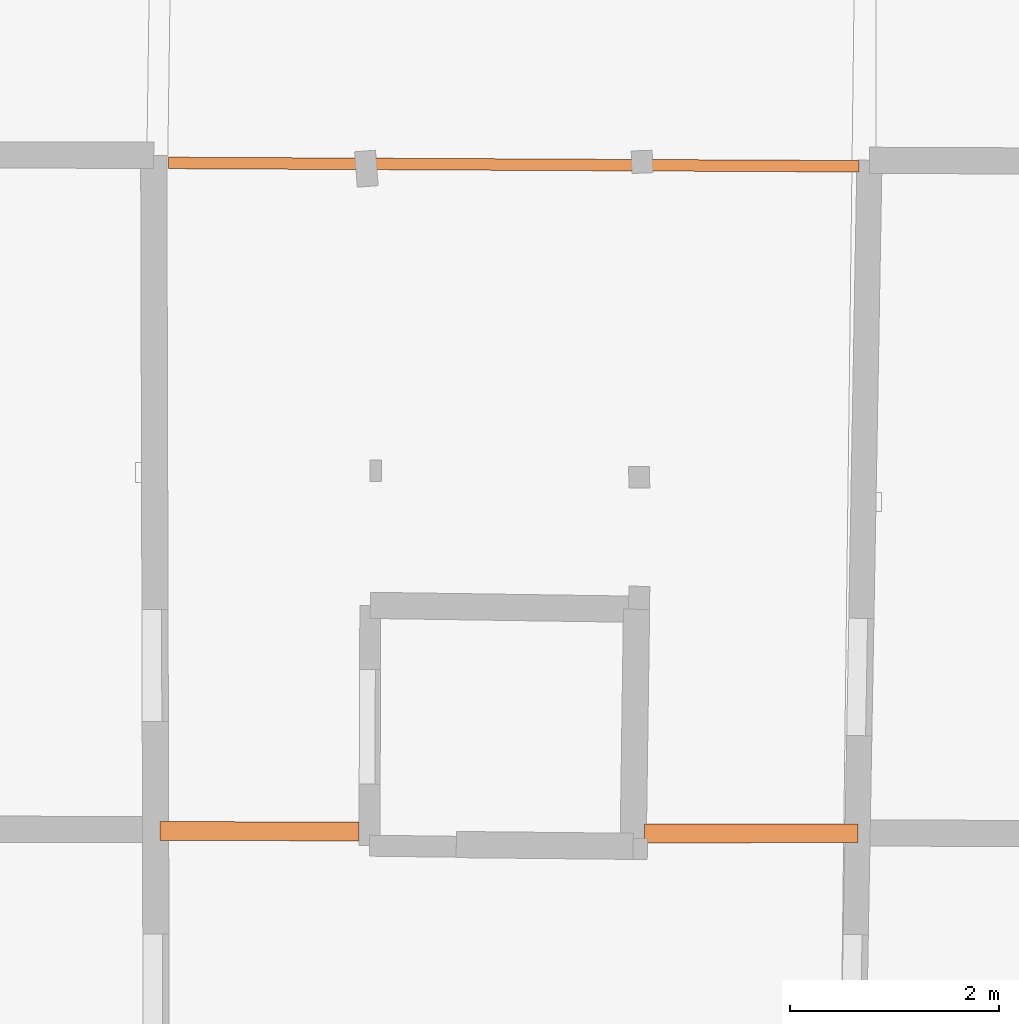
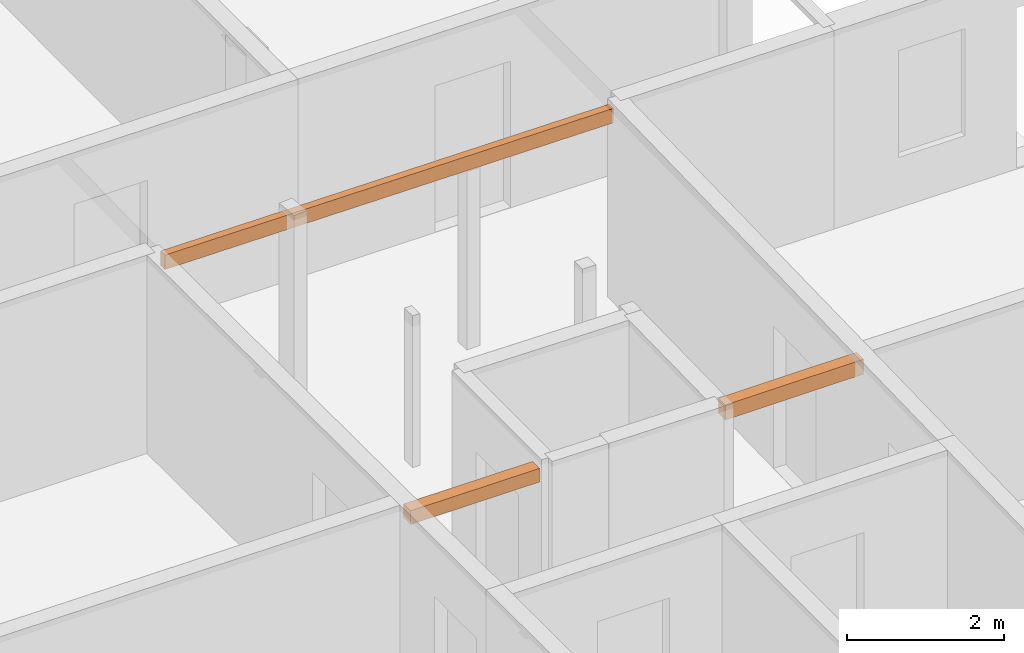
# One storey, part 17 of 17: 3 proxies.
"""IFC2X3 building model written with IfcOpenShell, lengths in metres."""

from ifc_helpers import new_model, entity, si_unit, converted_unit, derived_unit, direction, frame, origin, place, context, subcontext, project, spatial, polyline, outline, extrude, source, transform, mapped, material, type_object, type_shapes, element, save


model = new_model("IFC2X3")

# Units and contexts
model_context = context("Model", 3, precision=1e-05, world=origin(), true_north=direction((0.0, 1.0)))
body_context = subcontext(model_context, "Body", "Model", "MODEL_VIEW")
ifc_project = project(units=[si_unit("LENGTHUNIT", "METRE"), si_unit("AREAUNIT", "SQUARE_METRE"), si_unit("VOLUMEUNIT", "CUBIC_METRE"), converted_unit("PLANEANGLEUNIT", "DEGREE", entity("IfcRatioMeasure", 0.0174532925199433), si_unit("PLANEANGLEUNIT", "RADIAN"), dimensions=[0, 0, 0, 0, 0, 0, 0]), si_unit("MASSUNIT", "GRAM", prefix="KILO"), derived_unit("MASSDENSITYUNIT", [(si_unit("MASSUNIT", "GRAM", prefix="KILO"), 1), (si_unit("LENGTHUNIT", "METRE"), -3)]), derived_unit("MOMENTOFINERTIAUNIT", [(si_unit("LENGTHUNIT", "METRE"), 4)]), si_unit("TIMEUNIT", "SECOND"), si_unit("FREQUENCYUNIT", "HERTZ"), si_unit("THERMODYNAMICTEMPERATUREUNIT", "DEGREE_CELSIUS"), derived_unit("THERMALTRANSMITTANCEUNIT", [(si_unit("MASSUNIT", "GRAM", prefix="KILO"), 1), (si_unit("THERMODYNAMICTEMPERATUREUNIT", "KELVIN"), -1), (si_unit("TIMEUNIT", "SECOND"), -3)]), derived_unit("VOLUMETRICFLOWRATEUNIT", [(si_unit("LENGTHUNIT", "METRE"), 3), (si_unit("TIMEUNIT", "SECOND"), -1)]), si_unit("ELECTRICCURRENTUNIT", "AMPERE"), si_unit("ELECTRICVOLTAGEUNIT", "VOLT"), si_unit("POWERUNIT", "WATT"), si_unit("FORCEUNIT", "NEWTON", prefix="KILO"), si_unit("ILLUMINANCEUNIT", "LUX"), si_unit("LUMINOUSFLUXUNIT", "LUMEN"), si_unit("LUMINOUSINTENSITYUNIT", "CANDELA"), derived_unit("USERDEFINED", [(si_unit("MASSUNIT", "GRAM", prefix="KILO"), -1), (si_unit("LENGTHUNIT", "METRE"), -2), (si_unit("TIMEUNIT", "SECOND"), 3), (si_unit("LUMINOUSFLUXUNIT", "LUMEN"), 1)]), derived_unit("LINEARVELOCITYUNIT", [(si_unit("LENGTHUNIT", "METRE"), 1), (si_unit("TIMEUNIT", "SECOND"), -1)]), si_unit("PRESSUREUNIT", "PASCAL"), derived_unit("USERDEFINED", [(si_unit("LENGTHUNIT", "METRE"), -2), (si_unit("MASSUNIT", "GRAM", prefix="KILO"), 1), (si_unit("TIMEUNIT", "SECOND"), -2)]), derived_unit("LINEARFORCEUNIT", [(si_unit("MASSUNIT", "GRAM", prefix="KILO"), 1), (si_unit("LENGTHUNIT", "METRE"), 1), (si_unit("TIMEUNIT", "SECOND"), -2), (si_unit("LENGTHUNIT", "METRE"), -1)]), derived_unit("PLANARFORCEUNIT", [(si_unit("MASSUNIT", "GRAM", prefix="KILO"), 1), (si_unit("LENGTHUNIT", "METRE"), 1), (si_unit("TIMEUNIT", "SECOND"), -2), (si_unit("LENGTHUNIT", "METRE"), -2)])], contexts=[model_context])

# Site, building, storey
placement_1 = place(None, origin())
site = spatial("IfcSite", under=ifc_project, at=placement_1, CompositionType="ELEMENT")
building = spatial("IfcBuilding", under=site, at=placement_1, CompositionType="ELEMENT")
storey_placement = place(placement_1, frame((0.0, 0.0, 12.0782108306885)))
storey = spatial("IfcBuildingStorey", under=building, at=storey_placement, Name="Level 5", CompositionType="ELEMENT", Elevation=12.0782108306885)

# Proxies
ifc_material = material(Name="Beam default")
building_element_proxy_type_1 = type_object("IfcBuildingElementProxyType", Name="Beam:32", PredefinedType="NOTDEFINED")
shared_shape_1 = source(origin(), body_context, "Body", "SweptSolid", [
    extrude(outline(polyline([(1.90253720457366, -0.0900000035762787), (1.90253720457366, 0.0900000035762787), (0.0, 0.0900000035762787), (0.0, -0.0900000035762787), (1.90253720457366, -0.0900000035762787)])), origin(), (0.0, 0.0, 1.0), 0.211999893188477),
])
type_shapes(building_element_proxy_type_1, [shared_shape_1])
placement_2 = place(placement_1, frame((0.0, 0.0, 14.7980003356934)))
proxy_1_placement = place(placement_2, frame((2.89072581556911, 19.4247775039193, 0.0), z_axis=(0.0, 0.0, 1.0), x_axis=(0.999996314792275, -0.00271484840624375, 0.0)))
element("IfcBuildingElementProxy", 1, at=proxy_1_placement, inside=storey, type_object=building_element_proxy_type_1, material=ifc_material, Name="Beam:32", ObjectType="Beam", context=body_context, shape_type="MappedRepresentation", body=[
    mapped(shared_shape_1, transform((0.0, 0.0, 0.0), scale=1.0)),
])
building_element_proxy_type_2 = type_object("IfcBuildingElementProxyType", Name="Beam:287", PredefinedType="NOTDEFINED")
shared_shape_2 = source(origin(), body_context, "Body", "SweptSolid", [
    extrude(outline(polyline([(2.03499993246953, -0.0900000035762787), (2.03499993246953, 0.0900000035762787), (0.0, 0.0900000035762787), (0.0, -0.0900000035762787), (2.03499993246953, -0.0900000035762787)])), origin(), (0.0, 0.0, 1.0), 0.232999801635742),
])
type_shapes(building_element_proxy_type_2, [shared_shape_2])
placement_3 = place(placement_1, frame((0.0, 0.0, 14.8199996948242)))
proxy_2_placement = place(placement_3, frame((7.51940791210102, 19.4013116794604, 0.0), z_axis=(0.0, 0.0, 1.0), x_axis=(0.999999489566695, 0.00101037930928907, 0.0)))
element("IfcBuildingElementProxy", 2, at=proxy_2_placement, inside=storey, type_object=building_element_proxy_type_2, material=ifc_material, Name="Beam:287", ObjectType="Beam", context=body_context, shape_type="MappedRepresentation", body=[
    mapped(shared_shape_2, transform((0.0, 0.0, 0.0), scale=1.0)),
])
building_element_proxy_type_3 = type_object("IfcBuildingElementProxyType", Name="Beam:647", PredefinedType="NOTDEFINED")
shared_shape_3 = source(origin(), body_context, "Body", "SweptSolid", [
    extrude(outline(polyline([(6.5943018722124, -0.0549999997019768), (6.5943018722124, 0.0549999997019768), (0.0, 0.0549999997019768), (0.0, -0.0549999997019768), (6.5943018722124, -0.0549999997019768)])), origin(), (0.0, 0.0, 1.0), 0.225000381469727),
])
type_shapes(building_element_proxy_type_3, [shared_shape_3])
placement_4 = place(placement_1, frame((0.0, 0.0, 14.8520002365112)))
proxy_3_placement = place(placement_4, frame((2.97151348511511, 25.8029393975947, 0.0), z_axis=(0.0, 0.0, 1.0), x_axis=(0.999987898123664, -0.00491971607066017, 0.0)))
element("IfcBuildingElementProxy", 3, at=proxy_3_placement, inside=storey, type_object=building_element_proxy_type_3, material=ifc_material, Name="Beam:647", ObjectType="Beam", context=body_context, shape_type="MappedRepresentation", body=[
    mapped(shared_shape_3, transform((0.0, 0.0, 0.0), scale=1.0)),
])

save(model, "model.ifc")
